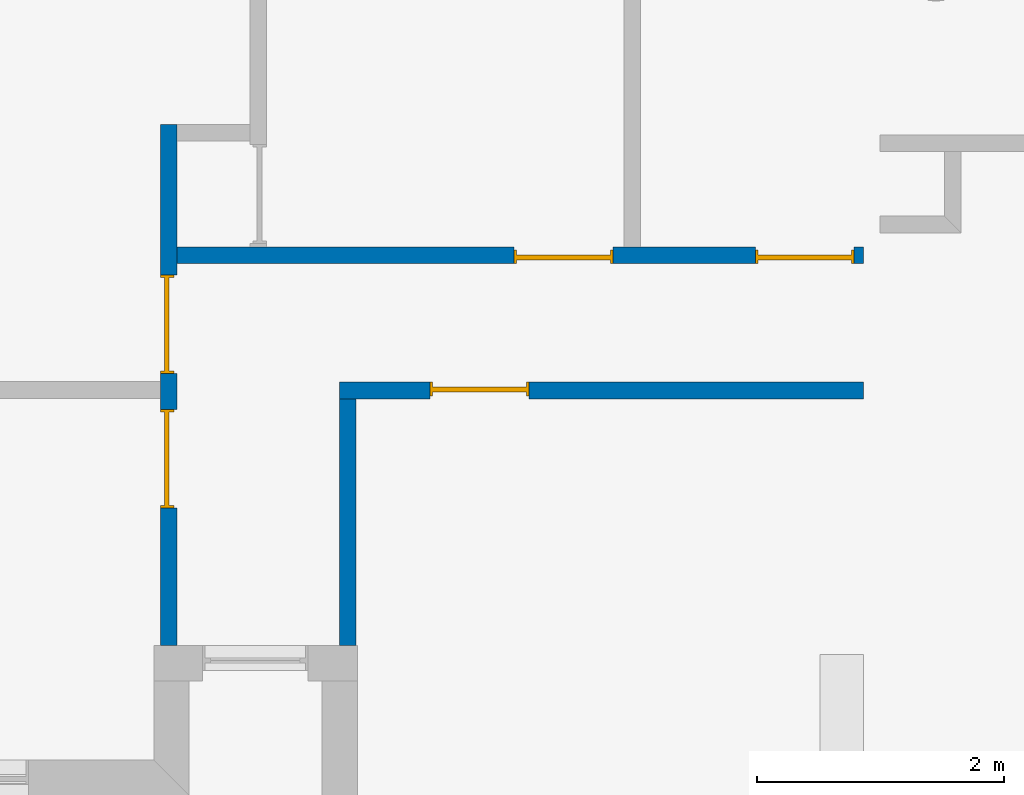
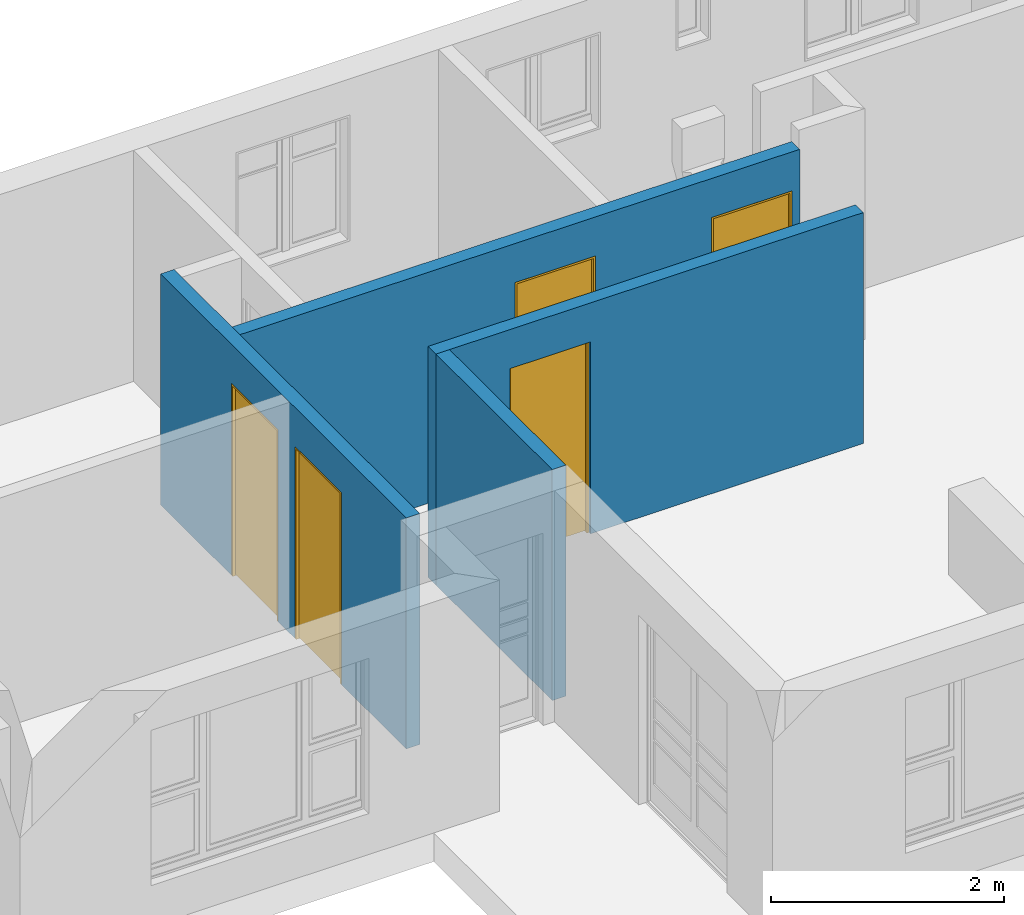
# One storey, part 3 of 15: 5 doors, 4 walls, 5 openings.
"""IFC4 building model written with IfcOpenShell, lengths in millimetres."""

from ifc_helpers import new_model, entity, si_unit, converted_unit, frame, origin_with_axes, origin_2d_with_axis, place, context, subcontext, project, spatial, line, indexed_curve, outline, extrude, polygons, source, transform, mapped, material, layer, layer_set, layer_usage, type_object, type_shapes, element, fill, save


model = new_model("IFC4")

# Units and contexts
model_context = context("Model", 3, precision=1e-05, world=origin_with_axes())
plan_context = context("Plan", 2, precision=1e-05, world=origin_2d_with_axis())
body_context = subcontext(model_context, "Body", "Model", "MODEL_VIEW")
ifc_project = project(units=[si_unit("VOLUMEUNIT", "CUBIC_METRE"), si_unit("LENGTHUNIT", "METRE", prefix="MILLI"), converted_unit("PLANEANGLEUNIT", "degree", entity("IfcReal", 0.0174532925199433), si_unit("PLANEANGLEUNIT", "RADIAN"), dimensions=[0, 0, 0, 0, 0, 0, 0]), si_unit("AREAUNIT", "SQUARE_METRE")], contexts=[model_context, plan_context])

# Site, building, storey
site_placement = place(None, origin_with_axes())
site = spatial("IfcSite", under=ifc_project, at=site_placement)
building_placement = place(site_placement, origin_with_axes())
building = spatial("IfcBuilding", under=site, at=building_placement, Name="Building")
storey_placement = place(building_placement, origin_with_axes())
storey = spatial("IfcBuildingStorey", under=building, at=storey_placement, Name="EXISTING")

# Wall, openings, doors
ifc_material = material()
ifc_layer = layer(ifc_material, 135.0)
ifc_layer_set = layer_set([ifc_layer])
ifc_layer_usage_1 = layer_usage(ifc_layer_set, "AXIS2", "POSITIVE", 0.0)
wall_type = type_object("IfcWallType", Name="WAL135", PredefinedType="NOTDEFINED", material=ifc_layer_set)
wall_1_placement = place(storey_placement, frame((4419.12078857422, 2611.66715621948, 0.0), z_axis=(0.0, 0.0, 1.0), x_axis=(0.999999999999993, 1.19209282445353e-07, 0.0)))
wall_1 = element("IfcWall", 1, at=wall_1_placement, inside=storey, type_object=wall_type, material=ifc_layer_usage_1, Name="Wall", context=body_context, shape_type="SweptSolid", body=[
    extrude(outline(indexed_curve([(0.0, 0.0), (0.0, 135.0), (5560.00042592877, 135.0), (5560.00042592877, 0.0), (0.0, 0.0)], self_intersect=False)), origin_with_axes(), (0.0, 0.0, 1.0), 2425.00019073486),
])
shared_shape_1 = source(origin_with_axes(), body_context, "Body", "SweptSolid", [
    extrude(outline(indexed_curve([(0.0, 0.0), (800.001098632812, 0.0), (800.001098632812, 2015.00024414062), (0.0, 2015.00024414062)], segments=[line(1, 2, 3, 4, 1)])), frame((-1.78813922957488e-06, -600.0, 0.0), z_axis=(0.0, -1.0, 0.0), x_axis=(1.0, 0.0, 0.0)), (0.0, 0.0, -1.0), 1200.0),
])
opening_1_placement = place(wall_1_placement, frame((4685.00137969837, 53.7485259770061, 0.0), z_axis=(0.0, 0.0, 1.0), x_axis=(0.999999999999993, 1.1920928244535e-07, 0.0)))
opening_1 = element("IfcOpeningElement", 2, at=opening_1_placement, cuts=wall_1, Name="Opening", PredefinedType="OPENING", context=body_context, shape_type="MappedRepresentation", body=[
    mapped(shared_shape_1, transform((0.0, 0.0, 0.0), x_axis=(1.0, 0.0, 0.0), y_axis=(0.0, 1.0, 0.0), z_axis=(0.0, 0.0, 1.0), scale=1.0)),
])
opening_2_placement = place(wall_1_placement, frame((2730.00001907348, -0.000206109271871924, 0.0), z_axis=(0.0, 0.0, 1.0), x_axis=(0.999999999999993, 1.19209282445351e-07, 0.0)))
opening_2 = element("IfcOpeningElement", 3, at=opening_2_placement, cuts=wall_1, Name="Opening", PredefinedType="OPENING", context=body_context, shape_type="MappedRepresentation", body=[
    mapped(shared_shape_1, transform((0.0, 0.0, 0.0), x_axis=(1.0, 0.0, 0.0), y_axis=(0.0, 1.0, 0.0), z_axis=(0.0, 0.0, 1.0), scale=1.0)),
])
door_type = type_object("IfcDoorType", OperationType="NOTDEFINED", PredefinedType="DOOR")
shared_shape_2 = source(origin_with_axes(), body_context, "Body", "Tessellation", [
    polygons([(0.000119209282274824, -53.7499732971191, 0.0), (20.0005760192871, -53.7499732971191, 0.0), (0.000119209282274824, -53.75, 1994.99987792969), (20.0005760192871, -53.75, 1994.99987792969), (0.000119209282274824, 56.2500038146973, 0.0), (20.0005760192871, 56.2500076293945, 0.0), (0.000119209282274824, 56.2499351501465, 1994.99987792969), (20.0005760192871, 56.249942779541, 1994.99987792969), (799.999328613281, -53.7499656677246, 1994.99987792969), (-0.0017881392268464, -53.75, 1994.99987792969), (799.999328613281, -53.7499656677246, 2015.00024414062), (799.999328613281, 56.2499809265137, 1994.99987792969), (-0.0017881392268464, 56.2499351501465, 1994.99987792969), (799.999328613281, 56.2499809265137, 2015.00024414062), (-0.0017881392268464, 56.2499351501465, 2014.99975585938), (-0.0017881392268464, -53.75, 2014.99975585938), (779.996948242188, -53.7499656677246, 0.0), (779.996948242188, -53.7499923706055, 1994.99987792969), (799.999328613281, -53.7499656677246, 0.0), (779.996948242188, 56.2499771118164, 0.0), (779.996948242188, 56.249942779541, 1994.99987792969), (799.999328613281, 56.2499809265137, 0.0), (799.999328613281, 56.2499465942383, 1994.99987792969), (799.999328613281, -53.7499923706055, 1994.99987792969), (779.998840332031, -23.7499713897705, 1994.99987792969), (779.996948242188, -23.749942779541, 9.99998950958252), (19.9986686706543, -23.749979019165, 1994.99987792969), (779.998840332031, 16.2500343322754, 1994.99987792969), (779.996948242188, 16.2500343322754, 9.99998950958252), (19.9986686706543, 16.2500305175781, 1994.99987792969), (19.9967613220215, 16.2500305175781, 9.99998950958252), (19.9967613220215, -23.7499465942383, 9.99998950958252)], [[[1, 2, 4, 3]], [[3, 4, 8, 7]], [[7, 8, 6, 5]], [[5, 6, 2, 1]], [[3, 7, 5, 1]], [[8, 4, 2, 6]], [[10, 13, 12, 9]], [[9, 11, 16, 10]], [[12, 14, 11, 9]], [[13, 15, 14, 12]], [[15, 16, 11, 14]], [[10, 16, 15, 13]], [[18, 21, 20, 17]], [[17, 19, 24, 18]], [[20, 22, 19, 17]], [[21, 23, 22, 20]], [[23, 24, 19, 22]], [[18, 24, 23, 21]], [[26, 29, 28, 25]], [[25, 27, 32, 26]], [[28, 30, 27, 25]], [[29, 31, 30, 28]], [[31, 32, 27, 30]], [[26, 32, 31, 29]]], closed=True),
])
type_shapes(door_type, [shared_shape_2])
door_1_placement = place(opening_1_placement, frame((1.77635683940025e-12, 0.0, 0.0), z_axis=(0.0, 0.0, 1.0), x_axis=(1.0, -2.64697796016969e-23, 0.0)))
door_1 = element("IfcDoor", 4, at=door_1_placement, inside=storey, type_object=door_type, Name="Door", context=body_context, shape_type="MappedRepresentation", body=[
    mapped(shared_shape_2, transform((0.0, 0.0, 0.0), x_axis=(1.0, 0.0, 0.0), y_axis=(0.0, 1.0, 0.0), z_axis=(0.0, 0.0, 1.0), scale=1.0)),
])
fill(opening_1, door_1)
door_2_placement = place(opening_2_placement, frame((0.000966489180243002, 53.7494419775162, 0.0), z_axis=(0.0, 0.0, 1.0), x_axis=(1.0, -1.27054942088145e-21, 0.0)))
door_2 = element("IfcDoor", 5, at=door_2_placement, inside=storey, type_object=door_type, Name="Door", context=body_context, shape_type="MappedRepresentation", body=[
    mapped(shared_shape_2, transform((0.0, 0.0, 0.0), x_axis=(1.0, 0.0, 0.0), y_axis=(0.0, 1.0, 0.0), z_axis=(0.0, 0.0, 1.0), scale=1.0)),
])
fill(opening_2, door_2)

# Wall, opening, door
ifc_layer_usage_2 = layer_usage(ifc_layer_set, "AXIS2", "POSITIVE", 0.0)
wall_2_placement = place(storey_placement, frame((5734.1194152832, 1516.66736602783, 0.0), z_axis=(0.0, 0.0, 1.0), x_axis=(0.999999999999993, 1.19209282445353e-07, 0.0)))
wall_2 = element("IfcWall", 6, at=wall_2_placement, inside=storey, type_object=wall_type, material=ifc_layer_usage_2, Name="Wall", context=body_context, shape_type="SweptSolid", body=[
    extrude(outline(indexed_curve([(0.0, 0.0), (0.0, 135.0), (4245.00137778396, 135.0), (4245.00137778396, 0.0), (0.0, 0.0)], self_intersect=False)), origin_with_axes(), (0.0, 0.0, 1.0), 2425.00019073486),
])
opening_3_placement = place(wall_2_placement, frame((735.002050250767, 78.7499266860505, 0.0), z_axis=(0.0, 0.0, 1.0), x_axis=(1.0, 3.97046694025453e-23, 0.0)))
opening_3 = element("IfcOpeningElement", 7, at=opening_3_placement, cuts=wall_2, Name="Opening", PredefinedType="OPENING", context=body_context, shape_type="MappedRepresentation", body=[
    mapped(shared_shape_1, transform((0.0, 0.0, 0.0), x_axis=(1.0, 0.0, 0.0), y_axis=(0.0, 1.0, 0.0), z_axis=(0.0, 0.0, 1.0), scale=1.0)),
])
door_3_placement = place(opening_3_placement, frame((-8.88178419700125e-13, 0.0, 0.0), z_axis=(0.0, 0.0, 1.0), x_axis=(1.0, -1.32348898008484e-23, 0.0)))
door_3 = element("IfcDoor", 8, at=door_3_placement, inside=storey, type_object=door_type, Name="Door", context=body_context, shape_type="MappedRepresentation", body=[
    mapped(shared_shape_2, transform((0.0, 0.0, 0.0), x_axis=(1.0, 0.0, 0.0), y_axis=(0.0, 1.0, 0.0), z_axis=(0.0, 0.0, 1.0), scale=1.0)),
])
fill(opening_3, door_3)

# Wall
ifc_layer_usage_3 = layer_usage(ifc_layer_set, "AXIS2", "POSITIVE", 0.0)
wall_3_placement = place(storey_placement, frame((5734.1194152832, 1516.66736602783, 0.0), z_axis=(0.0, 0.0, 1.0), x_axis=(3.13916473260163e-07, -0.999999999999951, 0.0)))
element("IfcWall", 9, at=wall_3_placement, inside=storey, type_object=wall_type, material=ifc_layer_usage_3, Name="Wall", context=body_context, shape_type="SweptSolid", body=[
    extrude(outline(indexed_curve([(0.0, 0.0), (0.0, 135.0), (2000.00023841862, 135.0), (2000.00023841862, 0.0), (0.0, 0.0)], self_intersect=False)), origin_with_axes(), (0.0, 0.0, 1.0), 2425.00019073486),
])

# Wall, openings, doors
ifc_layer_usage_4 = layer_usage(ifc_layer_set, "AXIS2", "POSITIVE", 0.0)
wall_4_placement = place(storey_placement, frame((4284.11817550659, 3741.66679382324, 0.0), z_axis=(0.0, 0.0, 1.0), x_axis=(3.13916473260163e-07, -0.999999999999951, 0.0)))
wall_4 = element("IfcWall", 10, at=wall_4_placement, inside=storey, type_object=wall_type, material=ifc_layer_usage_4, Name="Wall", context=body_context, shape_type="SweptSolid", body=[
    extrude(outline(indexed_curve([(0.0, 0.0), (0.0, 135.0), (4224.99989165381, 135.0), (4224.99989165381, 0.0), (0.0, 0.0)], self_intersect=False)), origin_with_axes(), (0.0, 0.0, 1.0), 2425.00019073486),
])
opening_4_placement = place(wall_4_placement, frame((1220.00098228464, 9.38587527699042e-05, 0.0), z_axis=(0.0, 0.0, 1.0), x_axis=(1.0, 0.0, 0.0)))
opening_4 = element("IfcOpeningElement", 11, at=opening_4_placement, cuts=wall_4, Name="Opening", PredefinedType="OPENING", context=body_context, shape_type="MappedRepresentation", body=[
    mapped(shared_shape_1, transform((0.0, 0.0, 0.0), x_axis=(1.0, 0.0, 0.0), y_axis=(0.0, 1.0, 0.0), z_axis=(0.0, 0.0, 1.0), scale=1.0)),
])
opening_5_placement = place(wall_4_placement, frame((2309.99994277973, 0.000228527280654589, 0.0), z_axis=(0.0, 0.0, 1.0), x_axis=(1.0, 0.0, 0.0)))
opening_5 = element("IfcOpeningElement", 12, at=opening_5_placement, cuts=wall_4, Name="Opening", PredefinedType="OPENING", context=body_context, shape_type="MappedRepresentation", body=[
    mapped(shared_shape_1, transform((0.0, 0.0, 0.0), x_axis=(1.0, 0.0, 0.0), y_axis=(0.0, 1.0, 0.0), z_axis=(0.0, 0.0, 1.0), scale=1.0)),
])
door_4_placement = place(opening_4_placement, frame((1.68728728766609e-05, 53.7495613098118, 0.0), z_axis=(0.0, 0.0, 1.0), x_axis=(1.0, 0.0, 0.0)))
door_4 = element("IfcDoor", 13, at=door_4_placement, inside=storey, type_object=door_type, Name="Door", context=body_context, shape_type="MappedRepresentation", body=[
    mapped(shared_shape_2, transform((0.0, 0.0, 0.0), x_axis=(1.0, 0.0, 0.0), y_axis=(0.0, 1.0, 0.0), z_axis=(0.0, 0.0, 1.0), scale=1.0)),
])
fill(opening_4, door_4)
door_5_placement = place(opening_5_placement, frame((1.68728726546163e-05, 53.7495613098127, 0.0), z_axis=(0.0, 0.0, 1.0), x_axis=(1.0, 0.0, 0.0)))
door_5 = element("IfcDoor", 14, at=door_5_placement, inside=storey, type_object=door_type, Name="Door", context=body_context, shape_type="MappedRepresentation", body=[
    mapped(shared_shape_2, transform((0.0, 0.0, 0.0), x_axis=(1.0, 0.0, 0.0), y_axis=(0.0, 1.0, 0.0), z_axis=(0.0, 0.0, 1.0), scale=1.0)),
])
fill(opening_5, door_5)

save(model, "model.ifc")
